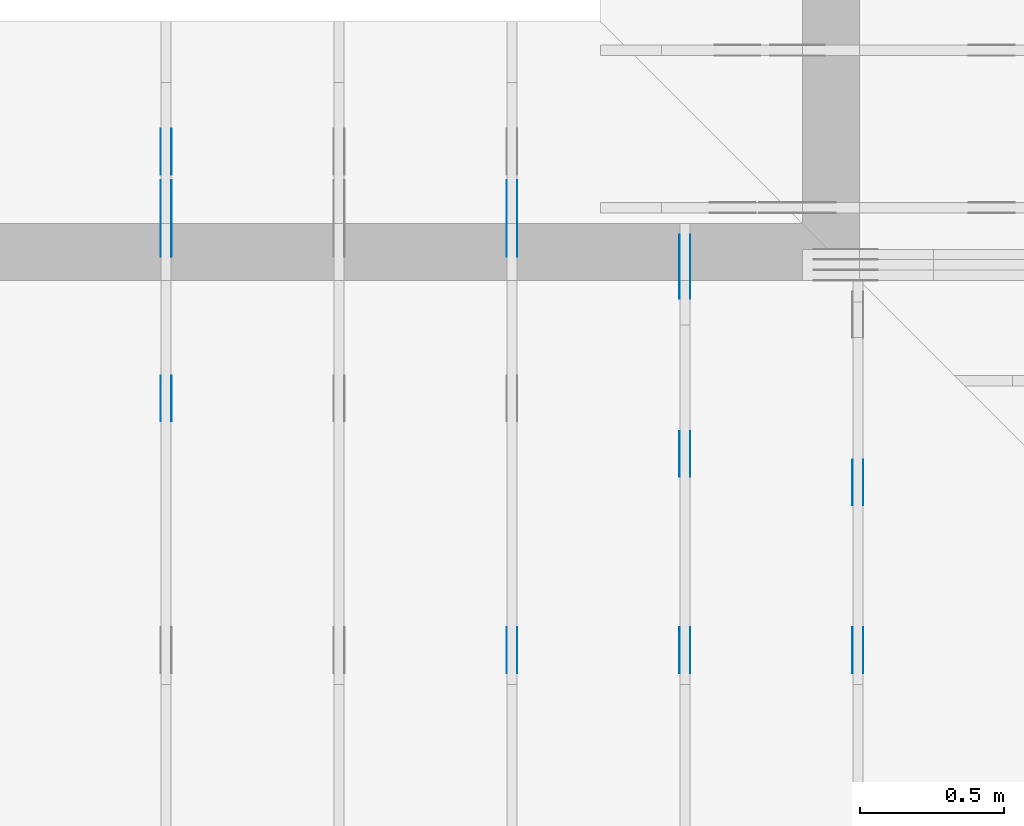
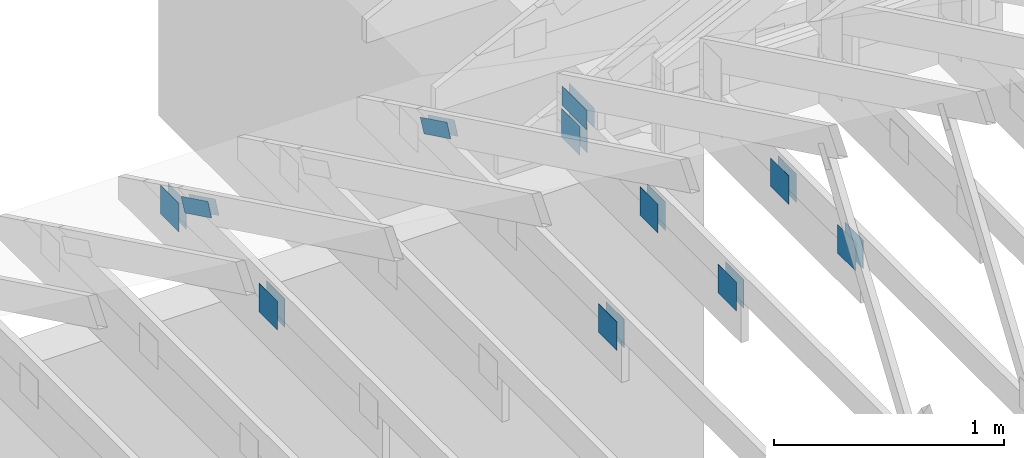
# One storey, part 96 of 159: 22 plates, 4 elements without a shape of their own.
"""IFC2X3 building model written with IfcOpenShell, lengths in millimetres."""

from ifc_helpers import new_model, si_unit, frame, origin, origin_with_axes, origin_2d, place, context, project, spatial, faceted_brep, element, aggregate, save


model = new_model("IFC2X3")

# Units and contexts
model_context = context("Model", 3, precision=1e-05, world=origin())
plan_context = context("Plan", 2, precision=1e-05, world=origin_2d())
ifc_project = project(units=[si_unit("LENGTHUNIT", "METRE", prefix="MILLI"), si_unit("AREAUNIT", "SQUARE_METRE"), si_unit("VOLUMEUNIT", "CUBIC_METRE"), si_unit("SOLIDANGLEUNIT", "STERADIAN"), si_unit("PLANEANGLEUNIT", "RADIAN"), si_unit("MASSUNIT", "GRAM"), si_unit("TIMEUNIT", "SECOND"), si_unit("THERMODYNAMICTEMPERATUREUNIT", "DEGREE_CELSIUS"), si_unit("LUMINOUSINTENSITYUNIT", "LUMEN")], contexts=[model_context, plan_context])

# Site, building, storey
site_placement = place(None, origin_with_axes())
site = spatial("IfcSite", under=ifc_project, at=site_placement, CompositionType="ELEMENT")
building_placement = place(site_placement, origin_with_axes())
building = spatial("IfcBuilding", under=site, at=building_placement, Name="Plan 1", CompositionType="ELEMENT")
storey_placement = place(building_placement, origin_with_axes())
storey = spatial("IfcBuildingStorey", under=building, at=storey_placement, Name="Etasje 1", CompositionType="ELEMENT", Elevation=0.0)

# Assembly, plates
assembly_1_placement = place(storey_placement, frame((10875.02226140475, -699.9989301294845, 1.1021457184401395e-15), z_axis=(-1.0, 1.836909530733566e-16, 6.123031769111886e-17), x_axis=(-1.836909530733566e-16, -1.0, 0.0)))
assembly_1 = element("IfcElementAssembly", 1, at=assembly_1_placement, inside=storey, Name="T4 (96)", AssemblyPlace="FACTORY", PredefinedType="TRUSS")
plate_1_placement = place(assembly_1_placement, frame((-8880.4990234375, 147.0, 0.0), z_axis=(0.0, 0.0, 1.0), x_axis=(1.0, 0.0, 0.0)))
plate_1 = element("IfcPlate", 2, at=plate_1_placement, Name="GNT100S 152x159", context=model_context, shape_type="Brep", body=[
    faceted_brep([(159.0, 152.0, 1.0), (0.0, 152.0, 1.0), (0.0, 0.0, 1.0), (159.0, 0.0, 1.0), (0.0, 152.0, 0.0), (159.0, 152.0, 1.9471241025775798e-14), (159.0, 0.0, 1.9471241025775798e-14), (0.0, 0.0, 0.0), (159.00009331759065, -2.9206878680260863e-14, 1.7883464603583392e-30), (159.00009331759065, -2.9145648362569744e-14, 1.0), (9.331759065389633e-05, 6.121317609395314e-17, 1.0), (9.331759065389633e-05, -1.714159716572357e-20, 1.0495854401904369e-36), (159.00009331759065, 152.0, 0.0), (159.00009331759065, 152.0, 1.0), (159.00009331759065, 0.0, 1.0), (159.00009331759065, 0.0, 0.0), (9.331759065389633e-05, 152.0, 0.0), (9.331759065389633e-05, 152.0, 1.0), (159.00009331759065, 152.0, 1.0), (159.00009331759065, 152.0, 0.0), (9.331759065389633e-05, 0.0, 0.0), (9.331759065395756e-05, -7.498303609110687e-33, 1.0), (9.331759067257158e-05, 152.0, 1.0), (9.331759067251035e-05, 152.0, -1.1397420192804459e-30)], [[[0, 1, 2, 3]], [[4, 5, 6, 7]], [[8, 9, 10, 11]], [[12, 13, 14, 15]], [[16, 17, 18, 19]], [[20, 21, 22, 23]]]),
])
plate_2_placement = place(assembly_1_placement, frame((-8880.4990234375, 147.0, -37.0), z_axis=(0.0, 0.0, 1.0), x_axis=(1.0, 0.0, 0.0)))
plate_2 = element("IfcPlate", 3, at=plate_2_placement, Name="GNT100S 152x159", context=model_context, shape_type="Brep", body=[
    faceted_brep([(159.0, 152.0, 1.0), (0.0, 152.0, 1.0), (0.0, 0.0, 1.0), (159.0, 0.0, 1.0), (0.0, 152.0, 0.0), (159.0, 152.0, 1.9471241025775798e-14), (159.0, 0.0, 1.9471241025775798e-14), (0.0, 0.0, 0.0), (159.00009331759065, -2.9206878680260863e-14, 1.7883464603583392e-30), (159.00009331759065, -2.9145648362569744e-14, 1.0), (9.331759065389633e-05, 6.121317609395314e-17, 1.0), (9.331759065389633e-05, -1.714159716572357e-20, 1.0495854401904369e-36), (159.00009331759065, 152.0, 0.0), (159.00009331759065, 152.0, 1.0), (159.00009331759065, 0.0, 1.0), (159.00009331759065, 0.0, 0.0), (9.331759065389633e-05, 152.0, 0.0), (9.331759065389633e-05, 152.0, 1.0), (159.00009331759065, 152.0, 1.0), (159.00009331759065, 152.0, 0.0), (9.331759065389633e-05, 0.0, 0.0), (9.331759065395756e-05, -7.498303609110687e-33, 1.0), (9.331759067257158e-05, 152.0, 1.0), (9.331759067251035e-05, 152.0, -1.1397420192804459e-30)], [[[0, 1, 2, 3]], [[4, 5, 6, 7]], [[8, 9, 10, 11]], [[12, 13, 14, 15]], [[16, 17, 18, 19]], [[20, 21, 22, 23]]]),
])
plate_3_placement = place(assembly_1_placement, frame((-8139.998930119909, 299.0, 0.0), z_axis=(0.0, 0.0, 1.0), x_axis=(-1.0, 1.2246063538223773e-16, 0.0)))
plate_3 = element("IfcPlate", 4, at=plate_3_placement, Name="GNT100S 152x159", context=model_context, shape_type="Brep", body=[
    faceted_brep([(159.00009331759065, 151.99999999999997, 1.0), (9.331759065389633e-05, 151.99999999999997, 1.0), (9.331759065389633e-05, 0.0, 1.0), (159.00009331759065, 0.0, 1.0), (9.331759065389633e-05, 151.99999999999997, 1.1427731443815714e-20), (159.00009331759065, 151.99999999999997, 1.9471252453507242e-14), (159.00009331759065, 0.0, 1.9471252453507242e-14), (9.331759065389633e-05, 0.0, 1.1427731443815714e-20), (159.0, -2.92068615386637e-14, 1.788345410772899e-30), (159.0, -2.914563122097258e-14, 1.0), (1.1247455413666031e-32, 6.123031769111886e-17, 1.0), (0.0, 0.0, 0.0), (159.0, 152.0, 0.0), (159.0, 152.0, 1.0), (159.0, 0.0, 1.0), (159.0, 0.0, 0.0), (0.0, 151.99999999999997, 0.0), (0.0, 151.99999999999997, 1.0), (159.0, 152.0, 1.0), (159.0, 152.0, 0.0), (0.0, 0.0, 0.0), (6.123031769111886e-17, -7.498303609110687e-33, 1.0), (1.867524689579125e-14, 151.99999999999997, 1.0), (1.861401657810013e-14, 151.99999999999997, -1.1397421485848243e-30)], [[[0, 1, 2, 3]], [[4, 5, 6, 7]], [[8, 9, 10, 11]], [[12, 13, 14, 15]], [[16, 17, 18, 19]], [[20, 21, 22, 23]]]),
])
plate_4_placement = place(assembly_1_placement, frame((-8139.998930119909, 299.0, -37.0), z_axis=(0.0, 0.0, 1.0), x_axis=(-1.0, 1.2246063538223773e-16, 0.0)))
plate_4 = element("IfcPlate", 5, at=plate_4_placement, Name="GNT100S 152x159", context=model_context, shape_type="Brep", body=[
    faceted_brep([(159.00009331759065, 151.99999999999997, 1.0), (9.331759065389633e-05, 151.99999999999997, 1.0), (9.331759065389633e-05, 0.0, 1.0), (159.00009331759065, 0.0, 1.0), (9.331759065389633e-05, 151.99999999999997, 1.1427731443815714e-20), (159.00009331759065, 151.99999999999997, 1.9471252453507242e-14), (159.00009331759065, 0.0, 1.9471252453507242e-14), (9.331759065389633e-05, 0.0, 1.1427731443815714e-20), (159.0, -2.92068615386637e-14, 1.788345410772899e-30), (159.0, -2.914563122097258e-14, 1.0), (1.1247455413666031e-32, 6.123031769111886e-17, 1.0), (0.0, 0.0, 0.0), (159.0, 152.0, 0.0), (159.0, 152.0, 1.0), (159.0, 0.0, 1.0), (159.0, 0.0, 0.0), (0.0, 151.99999999999997, 0.0), (0.0, 151.99999999999997, 1.0), (159.0, 152.0, 1.0), (159.0, 152.0, 0.0), (0.0, 0.0, 0.0), (6.123031769111886e-17, -7.498303609110687e-33, 1.0), (1.867524689579125e-14, 151.99999999999997, 1.0), (1.861401657810013e-14, 151.99999999999997, -1.1397421485848243e-30)], [[[0, 1, 2, 3]], [[4, 5, 6, 7]], [[8, 9, 10, 11]], [[12, 13, 14, 15]], [[16, 17, 18, 19]], [[20, 21, 22, 23]]]),
])
aggregate(assembly_1, [plate_1, plate_2, plate_3, plate_4])

assembly_2_placement = place(storey_placement, frame((10275.02226140475, -699.9989301294845, 1.1021457184401395e-15), z_axis=(-1.0, 1.836909530733566e-16, 6.123031769111886e-17), x_axis=(-1.836909530733566e-16, -1.0, 0.0)))
assembly_2 = element("IfcElementAssembly", 6, at=assembly_2_placement, inside=storey, Name="T3 (95)", AssemblyPlace="FACTORY", PredefinedType="TRUSS")
plate_5_placement = place(assembly_2_placement, frame((-9656.759102067255, 319.5, 0.0), z_axis=(0.0, 0.0, 1.0), x_axis=(1.0, 0.0, 0.0)))
plate_5 = element("IfcPlate", 7, at=plate_5_placement, Name="GNT100S 103x218", context=model_context, shape_type="Brep", body=[
    faceted_brep([(218.0003130047553, 103.0, 1.0), (0.00031300475529860705, 103.0, 1.0), (0.00031300475529860705, 0.0, 1.0), (218.0003130047553, 0.0, 1.0), (0.00031300475529860705, 103.0, 3.833076121152926e-20), (218.0003130047553, 103.0, 2.6696456844089035e-14), (218.0003130047553, 0.0, 2.6696456844089035e-14), (0.00031300475529860705, 0.0, 3.833076121152926e-20), (218.0, -4.0044627769991736e-14, 2.4519452801791947e-30), (218.0, -3.998339745230062e-14, 1.0), (1.1247455413666031e-32, 6.123031769111886e-17, 1.0), (0.0, 0.0, 0.0), (218.0, 103.0, 0.0), (218.0, 103.0, 1.0), (218.0, 0.0, 1.0), (218.0, 0.0, 0.0), (0.0, 103.0, 0.0), (-3.7491518045553436e-33, 103.0, 1.0), (218.0, 102.99999999999999, 1.0), (218.0, 102.99999999999999, -7.888609052210118e-31), (0.0, 0.0, 0.0), (6.123031769111886e-17, -7.498303609110687e-33, 1.0), (1.2674675762061605e-14, 103.0, 1.0), (1.2613445444370486e-14, 103.0, -7.723252717384008e-31)], [[[0, 1, 2, 3]], [[4, 5, 6, 7]], [[8, 9, 10, 11]], [[12, 13, 14, 15]], [[16, 17, 18, 19]], [[20, 21, 22, 23]]]),
])
plate_6_placement = place(assembly_2_placement, frame((-9656.759102067255, 319.5, -37.0), z_axis=(0.0, 0.0, 1.0), x_axis=(1.0, 0.0, 0.0)))
plate_6 = element("IfcPlate", 8, at=plate_6_placement, Name="GNT100S 103x218", context=model_context, shape_type="Brep", body=[
    faceted_brep([(218.0003130047553, 103.0, 1.0), (0.00031300475529860705, 103.0, 1.0), (0.00031300475529860705, 0.0, 1.0), (218.0003130047553, 0.0, 1.0), (0.00031300475529860705, 103.0, 3.833076121152926e-20), (218.0003130047553, 103.0, 2.6696456844089035e-14), (218.0003130047553, 0.0, 2.6696456844089035e-14), (0.00031300475529860705, 0.0, 3.833076121152926e-20), (218.0, -4.0044627769991736e-14, 2.4519452801791947e-30), (218.0, -3.998339745230062e-14, 1.0), (1.1247455413666031e-32, 6.123031769111886e-17, 1.0), (0.0, 0.0, 0.0), (218.0, 103.0, 0.0), (218.0, 103.0, 1.0), (218.0, 0.0, 1.0), (218.0, 0.0, 0.0), (0.0, 103.0, 0.0), (-3.7491518045553436e-33, 103.0, 1.0), (218.0, 102.99999999999999, 1.0), (218.0, 102.99999999999999, -7.888609052210118e-31), (0.0, 0.0, 0.0), (6.123031769111886e-17, -7.498303609110687e-33, 1.0), (1.2674675762061605e-14, 103.0, 1.0), (1.2613445444370486e-14, 103.0, -7.723252717384008e-31)], [[[0, 1, 2, 3]], [[4, 5, 6, 7]], [[8, 9, 10, 11]], [[12, 13, 14, 15]], [[16, 17, 18, 19]], [[20, 21, 22, 23]]]),
])
plate_7_placement = place(assembly_2_placement, frame((-8139.998930129455, 299.0, 0.0), z_axis=(0.0, 0.0, 1.0), x_axis=(-1.0, 1.2246063538223773e-16, 0.0)))
plate_7 = element("IfcPlate", 9, at=plate_7_placement, Name="GNT100S 152x159", context=model_context, shape_type="Brep", body=[
    faceted_brep([(159.0000933080446, 151.99999999999997, 1.0), (9.330804459750652e-05, 151.99999999999997, 1.0), (9.330804459750652e-05, 0.0, 1.0), (159.0000933080446, 0.0, 1.0), (9.330804459750652e-05, 151.99999999999997, 1.1426562427684823e-20), (159.0000933080446, 151.99999999999997, 1.9471252452338226e-14), (159.0000933080446, 0.0, 1.9471252452338226e-14), (9.330804459750652e-05, 0.0, 1.1426562427684823e-20), (159.0, -2.92068615386637e-14, 1.788345410772899e-30), (159.0, -2.914563122097258e-14, 1.0), (1.1247455413666031e-32, 6.123031769111886e-17, 1.0), (0.0, 0.0, 0.0), (159.0, 152.0, 0.0), (159.0, 152.0, 1.0), (159.0, 0.0, 1.0), (159.0, 0.0, 0.0), (0.0, 151.99999999999997, 0.0), (0.0, 151.99999999999997, 1.0), (159.0, 152.0, 1.0), (159.0, 152.0, 0.0), (0.0, 0.0, 0.0), (6.123031769111886e-17, -7.498303609110687e-33, 1.0), (1.867524689579125e-14, 151.99999999999997, 1.0), (1.861401657810013e-14, 151.99999999999997, -1.1397421485848243e-30)], [[[0, 1, 2, 3]], [[4, 5, 6, 7]], [[8, 9, 10, 11]], [[12, 13, 14, 15]], [[16, 17, 18, 19]], [[20, 21, 22, 23]]]),
])
plate_8_placement = place(assembly_2_placement, frame((-8139.998930129455, 299.0, -37.0), z_axis=(0.0, 0.0, 1.0), x_axis=(-1.0, 1.2246063538223773e-16, 0.0)))
plate_8 = element("IfcPlate", 10, at=plate_8_placement, Name="GNT100S 152x159", context=model_context, shape_type="Brep", body=[
    faceted_brep([(159.0000933080446, 151.99999999999997, 1.0), (9.330804459750652e-05, 151.99999999999997, 1.0), (9.330804459750652e-05, 0.0, 1.0), (159.0000933080446, 0.0, 1.0), (9.330804459750652e-05, 151.99999999999997, 1.1426562427684823e-20), (159.0000933080446, 151.99999999999997, 1.9471252452338226e-14), (159.0000933080446, 0.0, 1.9471252452338226e-14), (9.330804459750652e-05, 0.0, 1.1426562427684823e-20), (159.0, -2.92068615386637e-14, 1.788345410772899e-30), (159.0, -2.914563122097258e-14, 1.0), (1.1247455413666031e-32, 6.123031769111886e-17, 1.0), (0.0, 0.0, 0.0), (159.0, 152.0, 0.0), (159.0, 152.0, 1.0), (159.0, 0.0, 1.0), (159.0, 0.0, 0.0), (0.0, 151.99999999999997, 0.0), (0.0, 151.99999999999997, 1.0), (159.0, 152.0, 1.0), (159.0, 152.0, 0.0), (0.0, 0.0, 0.0), (6.123031769111886e-17, -7.498303609110687e-33, 1.0), (1.867524689579125e-14, 151.99999999999997, 1.0), (1.861401657810013e-14, 151.99999999999997, -1.1397421485848243e-30)], [[[0, 1, 2, 3]], [[4, 5, 6, 7]], [[8, 9, 10, 11]], [[12, 13, 14, 15]], [[16, 17, 18, 19]], [[20, 21, 22, 23]]]),
])
plate_9_placement = place(assembly_2_placement, frame((-8979.4990234375, 147.0, 0.0), z_axis=(0.0, 0.0, 1.0), x_axis=(1.0, 0.0, 0.0)))
plate_9 = element("IfcPlate", 11, at=plate_9_placement, Name="GNT100S 152x159", context=model_context, shape_type="Brep", body=[
    faceted_brep([(159.0, 152.0, 1.0), (0.0, 152.0, 1.0), (0.0, 0.0, 1.0), (159.0, 0.0, 1.0), (0.0, 152.0, 0.0), (159.0, 152.0, 1.9471241025775798e-14), (159.0, 0.0, 1.9471241025775798e-14), (0.0, 0.0, 0.0), (159.0000933080446, 5.6058249612704683e-14, 1.7883464602509703e-30), (159.0000933080446, 5.61194799303958e-14, 1.0), (9.330804459750652e-05, 8.532634146905949e-14, 1.0), (9.330804459750652e-05, 8.526511115136837e-14, 1.0494780714342263e-36), (159.0000933080446, 152.0000000000001, 0.0), (159.0000933080446, 152.0000000000001, 1.0), (159.0000933080446, 8.526512829121202e-14, 1.0), (159.0000933080446, 8.526512829121202e-14, 0.0), (9.330804459750652e-05, 152.0000000000001, 0.0), (9.330804459750652e-05, 152.0000000000001, 1.0), (159.0000933080446, 152.0000000000001, 1.0), (159.0000933080446, 152.0000000000001, 0.0), (9.330804459750652e-05, 8.526512829121202e-14, 0.0), (9.330804459756775e-05, 8.526512829121202e-14, 1.0), (9.330804461618177e-05, 152.0000000000001, 1.0), (9.330804461612054e-05, 152.0000000000001, -1.1397420192804459e-30)], [[[0, 1, 2, 3]], [[4, 5, 6, 7]], [[8, 9, 10, 11]], [[12, 13, 14, 15]], [[16, 17, 18, 19]], [[20, 21, 22, 23]]]),
])
plate_10_placement = place(assembly_2_placement, frame((-8979.4990234375, 147.0, -37.0), z_axis=(0.0, 0.0, 1.0), x_axis=(1.0, 0.0, 0.0)))
plate_10 = element("IfcPlate", 12, at=plate_10_placement, Name="GNT100S 152x159", context=model_context, shape_type="Brep", body=[
    faceted_brep([(159.0, 152.0, 1.0), (0.0, 152.0, 1.0), (0.0, 0.0, 1.0), (159.0, 0.0, 1.0), (0.0, 152.0, 0.0), (159.0, 152.0, 1.9471241025775798e-14), (159.0, 0.0, 1.9471241025775798e-14), (0.0, 0.0, 0.0), (159.0000933080446, 5.6058249612704683e-14, 1.7883464602509703e-30), (159.0000933080446, 5.61194799303958e-14, 1.0), (9.330804459750652e-05, 8.532634146905949e-14, 1.0), (9.330804459750652e-05, 8.526511115136837e-14, 1.0494780714342263e-36), (159.0000933080446, 152.0000000000001, 0.0), (159.0000933080446, 152.0000000000001, 1.0), (159.0000933080446, 8.526512829121202e-14, 1.0), (159.0000933080446, 8.526512829121202e-14, 0.0), (9.330804459750652e-05, 152.0000000000001, 0.0), (9.330804459750652e-05, 152.0000000000001, 1.0), (159.0000933080446, 152.0000000000001, 1.0), (159.0000933080446, 152.0000000000001, 0.0), (9.330804459750652e-05, 8.526512829121202e-14, 0.0), (9.330804459756775e-05, 8.526512829121202e-14, 1.0), (9.330804461618177e-05, 152.0000000000001, 1.0), (9.330804461612054e-05, 152.0000000000001, -1.1397420192804459e-30)], [[[0, 1, 2, 3]], [[4, 5, 6, 7]], [[8, 9, 10, 11]], [[12, 13, 14, 15]], [[16, 17, 18, 19]], [[20, 21, 22, 23]]]),
])
plate_11_placement = place(assembly_2_placement, frame((-9659.9990234375, 147.0, 0.0), z_axis=(0.0, 0.0, 1.0), x_axis=(1.0, 0.0, 0.0)))
plate_11 = element("IfcPlate", 13, at=plate_11_placement, Name="GNT100S 152x159", context=model_context, shape_type="Brep", body=[
    faceted_brep([(159.0, 152.0, 1.0), (0.0, 152.0, 1.0), (0.0, 0.0, 1.0), (159.0, 0.0, 1.0), (0.0, 152.0, 0.0), (159.0, 152.0, 1.9471241025775798e-14), (159.0, 0.0, 1.9471241025775798e-14), (0.0, 0.0, 0.0), (159.0000933080446, 1.697450873343207e-13, 1.7883464602509703e-30), (159.0000933080446, 1.6980631765201183e-13, 1.0), (9.330804459750652e-05, 1.9901317919067552e-13, 1.0), (9.330804459750652e-05, 1.989519488729844e-13, 1.0494780714342263e-36), (159.0000933080446, 152.00000000000023, 0.0), (159.0000933080446, 152.00000000000023, 1.0), (159.0000933080446, 1.9895196601282805e-13, 1.0), (159.0000933080446, 1.9895196601282805e-13, 0.0), (9.330804459750652e-05, 152.00000000000023, 0.0), (9.330804459750652e-05, 152.00000000000023, 1.0), (159.0000933080446, 152.00000000000023, 1.0), (159.0000933080446, 152.00000000000023, 0.0), (9.330804459750652e-05, 1.9895196601282805e-13, 0.0), (9.330804459756775e-05, 1.9895196601282805e-13, 1.0), (9.330804461618177e-05, 152.00000000000023, 1.0), (9.330804461612054e-05, 152.00000000000023, -1.1397420192804459e-30)], [[[0, 1, 2, 3]], [[4, 5, 6, 7]], [[8, 9, 10, 11]], [[12, 13, 14, 15]], [[16, 17, 18, 19]], [[20, 21, 22, 23]]]),
])
plate_12_placement = place(assembly_2_placement, frame((-9659.9990234375, 147.0, -37.0), z_axis=(0.0, 0.0, 1.0), x_axis=(1.0, 0.0, 0.0)))
plate_12 = element("IfcPlate", 14, at=plate_12_placement, Name="GNT100S 152x159", context=model_context, shape_type="Brep", body=[
    faceted_brep([(159.0, 152.0, 1.0), (0.0, 152.0, 1.0), (0.0, 0.0, 1.0), (159.0, 0.0, 1.0), (0.0, 152.0, 0.0), (159.0, 152.0, 1.9471241025775798e-14), (159.0, 0.0, 1.9471241025775798e-14), (0.0, 0.0, 0.0), (159.0000933080446, 1.697450873343207e-13, 1.7883464602509703e-30), (159.0000933080446, 1.6980631765201183e-13, 1.0), (9.330804459750652e-05, 1.9901317919067552e-13, 1.0), (9.330804459750652e-05, 1.989519488729844e-13, 1.0494780714342263e-36), (159.0000933080446, 152.00000000000023, 0.0), (159.0000933080446, 152.00000000000023, 1.0), (159.0000933080446, 1.9895196601282805e-13, 1.0), (159.0000933080446, 1.9895196601282805e-13, 0.0), (9.330804459750652e-05, 152.00000000000023, 0.0), (9.330804459750652e-05, 152.00000000000023, 1.0), (159.0000933080446, 152.00000000000023, 1.0), (159.0000933080446, 152.00000000000023, 0.0), (9.330804459750652e-05, 1.9895196601282805e-13, 0.0), (9.330804459756775e-05, 1.9895196601282805e-13, 1.0), (9.330804461618177e-05, 152.00000000000023, 1.0), (9.330804461612054e-05, 152.00000000000023, -1.1397420192804459e-30)], [[[0, 1, 2, 3]], [[4, 5, 6, 7]], [[8, 9, 10, 11]], [[12, 13, 14, 15]], [[16, 17, 18, 19]], [[20, 21, 22, 23]]]),
])
aggregate(assembly_2, [plate_5, plate_6, plate_7, plate_8, plate_9, plate_10, plate_11, plate_12])

assembly_3_placement = place(storey_placement, frame((9675.022261404752, 9699.99999999999, 1.1021457184401395e-15), z_axis=(-1.0, 1.836909530733566e-16, 6.123031769111886e-17), x_axis=(-1.836909530733566e-16, -1.0, 0.0)))
assembly_3 = element("IfcElementAssembly", 15, at=assembly_3_placement, inside=storey, Name="T2 (94)", AssemblyPlace="FACTORY", PredefinedType="TRUSS")
plate_13_placement = place(assembly_3_placement, frame((584.1466632894789, 280.2959373746887, 0.0), z_axis=(0.0, 0.0, 1.0), x_axis=(0.8987940462991671, 0.43837114678907757, 0.0)))
plate_13 = element("IfcPlate", 16, at=plate_13_placement, Name="GNT100S 76x258", context=model_context, shape_type="Brep", body=[
    faceted_brep([(257.99998123479463, 76.00002691228985, 1.0), (0.0, 76.00002691228985, 1.0), (1.3453948213282274e-05, 1.802431262376558e-05, 1.0), (257.99999468874273, 1.802431262376558e-05, 1.0), (0.0, 76.00002691228985, 0.0), (257.99998123479463, 76.00002691228985, 3.159484163061836e-14), (257.99999468874273, 0.0, 3.1594843278197396e-14), (1.3453948213282274e-05, 0.0, 1.6475790465982693e-21), (258.00000746284013, 8.521039129974861e-06, 1.1615733003639174e-30), (258.00000746284013, 8.521039130036092e-06, 1.0), (7.462840130756376e-06, 8.521039177428358e-06, 1.0), (7.462840130756376e-06, 8.521039177367127e-06, 9.4039548065783e-38), (258.00000746284013, 76.00000852103915, 0.0), (258.00000746284013, 76.00000852103915, 1.0), (258.00000746284013, 8.52103914894542e-06, 1.0), (258.00000746284013, 8.52103914894542e-06, 0.0), (7.462840130756376e-06, 76.0000085210392, 0.0), (7.462840130756376e-06, 76.0000085210392, 1.0), (258.00000746284013, 76.00000852103913, 1.0), (258.00000746284013, 76.00000852103913, -1.5777218104420236e-30), (7.462840130756377e-06, 8.521039177367129e-06, -9.4039548065783e-38), (7.4628401308176075e-06, 8.521039177367129e-06, 1.0), (7.462840140124616e-06, 76.0000085210392, 1.0), (7.4628401400633854e-06, 76.0000085210392, -5.69871103679771e-31)], [[[0, 1, 2, 3]], [[4, 5, 6, 7]], [[8, 9, 10, 11]], [[12, 13, 14, 15]], [[16, 17, 18, 19]], [[20, 21, 22, 23]]]),
])
plate_14_placement = place(assembly_3_placement, frame((584.1466632894789, 280.2959373746887, -37.0), z_axis=(0.0, 0.0, 1.0), x_axis=(0.8987940462991671, 0.43837114678907757, 0.0)))
plate_14 = element("IfcPlate", 17, at=plate_14_placement, Name="GNT100S 76x258", context=model_context, shape_type="Brep", body=[
    faceted_brep([(257.99998123479463, 76.00002691228985, 1.0), (0.0, 76.00002691228985, 1.0), (1.3453948213282274e-05, 1.802431262376558e-05, 1.0), (257.99999468874273, 1.802431262376558e-05, 1.0), (0.0, 76.00002691228985, 0.0), (257.99998123479463, 76.00002691228985, 3.159484163061836e-14), (257.99999468874273, 0.0, 3.1594843278197396e-14), (1.3453948213282274e-05, 0.0, 1.6475790465982693e-21), (258.00000746284013, 8.521039129974861e-06, 1.1615733003639174e-30), (258.00000746284013, 8.521039130036092e-06, 1.0), (7.462840130756376e-06, 8.521039177428358e-06, 1.0), (7.462840130756376e-06, 8.521039177367127e-06, 9.4039548065783e-38), (258.00000746284013, 76.00000852103915, 0.0), (258.00000746284013, 76.00000852103915, 1.0), (258.00000746284013, 8.52103914894542e-06, 1.0), (258.00000746284013, 8.52103914894542e-06, 0.0), (7.462840130756376e-06, 76.0000085210392, 0.0), (7.462840130756376e-06, 76.0000085210392, 1.0), (258.00000746284013, 76.00000852103913, 1.0), (258.00000746284013, 76.00000852103913, -1.5777218104420236e-30), (7.462840130756377e-06, 8.521039177367129e-06, -9.4039548065783e-38), (7.4628401308176075e-06, 8.521039177367129e-06, 1.0), (7.462840140124616e-06, 76.0000085210392, 1.0), (7.4628401400633854e-06, 76.0000085210392, -5.69871103679771e-31)], [[[0, 1, 2, 3]], [[4, 5, 6, 7]], [[8, 9, 10, 11]], [[12, 13, 14, 15]], [[16, 17, 18, 19]], [[20, 21, 22, 23]]]),
])
plate_15_placement = place(assembly_3_placement, frame((2260.0, 299.0, 0.0), z_axis=(0.0, 0.0, 1.0), x_axis=(-1.0, 1.2246063538223773e-16, 0.0)))
plate_15 = element("IfcPlate", 18, at=plate_15_placement, Name="GNT100S 152x159", context=model_context, shape_type="Brep", body=[
    faceted_brep([(159.0, 152.0, 1.0), (0.0, 152.0, 1.0), (0.0, 0.0, 1.0), (159.0, 0.0, 1.0), (0.0, 152.0, 0.0), (159.0, 152.0, 1.9471241025775798e-14), (159.0, 0.0, 1.9471241025775798e-14), (0.0, 0.0, 0.0), (159.0, -2.92068615386637e-14, 1.788345410772899e-30), (159.0, -2.914563122097258e-14, 1.0), (1.1247455413666031e-32, 6.123031769111886e-17, 1.0), (0.0, 0.0, 0.0), (159.0, 152.00000000000003, 0.0), (159.0, 152.00000000000003, 1.0), (159.0, 0.0, 1.0), (159.0, 0.0, 0.0), (0.0, 152.0, 0.0), (0.0, 152.0, 1.0), (159.0, 152.00000000000003, 1.0), (159.0, 152.00000000000003, 0.0), (0.0, 0.0, 0.0), (6.123031769111886e-17, -7.498303609110687e-33, 1.0), (1.8675246895791253e-14, 152.0, 1.0), (1.8614016578100134e-14, 152.0, -1.1397421485848245e-30)], [[[0, 1, 2, 3]], [[4, 5, 6, 7]], [[8, 9, 10, 11]], [[12, 13, 14, 15]], [[16, 17, 18, 19]], [[20, 21, 22, 23]]]),
])
plate_16_placement = place(assembly_3_placement, frame((2260.0, 299.0, -37.0), z_axis=(0.0, 0.0, 1.0), x_axis=(-1.0, 1.2246063538223773e-16, 0.0)))
plate_16 = element("IfcPlate", 19, at=plate_16_placement, Name="GNT100S 152x159", context=model_context, shape_type="Brep", body=[
    faceted_brep([(159.0, 152.0, 1.0), (0.0, 152.0, 1.0), (0.0, 0.0, 1.0), (159.0, 0.0, 1.0), (0.0, 152.0, 0.0), (159.0, 152.0, 1.9471241025775798e-14), (159.0, 0.0, 1.9471241025775798e-14), (0.0, 0.0, 0.0), (159.0, -2.92068615386637e-14, 1.788345410772899e-30), (159.0, -2.914563122097258e-14, 1.0), (1.1247455413666031e-32, 6.123031769111886e-17, 1.0), (0.0, 0.0, 0.0), (159.0, 152.00000000000003, 0.0), (159.0, 152.00000000000003, 1.0), (159.0, 0.0, 1.0), (159.0, 0.0, 0.0), (0.0, 152.0, 0.0), (0.0, 152.0, 1.0), (159.0, 152.00000000000003, 1.0), (159.0, 152.00000000000003, 0.0), (0.0, 0.0, 0.0), (6.123031769111886e-17, -7.498303609110687e-33, 1.0), (1.8675246895791253e-14, 152.0, 1.0), (1.8614016578100134e-14, 152.0, -1.1397421485848245e-30)], [[[0, 1, 2, 3]], [[4, 5, 6, 7]], [[8, 9, 10, 11]], [[12, 13, 14, 15]], [[16, 17, 18, 19]], [[20, 21, 22, 23]]]),
])
aggregate(assembly_3, [plate_13, plate_14, plate_15, plate_16])

assembly_4_placement = place(storey_placement, frame((8475.022261404752, 9699.99999999999, 1.1021457184401395e-15), z_axis=(-1.0, 1.836909530733566e-16, 6.123031769111886e-17), x_axis=(-1.836909530733566e-16, -1.0, 0.0)))
assembly_4 = element("IfcElementAssembly", 20, at=assembly_4_placement, inside=storey, Name="T2 (92)", AssemblyPlace="FACTORY", PredefinedType="TRUSS")
plate_17_placement = place(assembly_4_placement, frame((584.1466632894789, 280.2959373746887, 0.0), z_axis=(0.0, 0.0, 1.0), x_axis=(0.8987940462991671, 0.43837114678907757, 0.0)))
plate_17 = element("IfcPlate", 21, at=plate_17_placement, Name="GNT100S 76x258", context=model_context, shape_type="Brep", body=[
    faceted_brep([(257.99998123479463, 76.00002691228985, 1.0), (0.0, 76.00002691228985, 1.0), (1.3453948213282274e-05, 1.802431262376558e-05, 1.0), (257.99999468874273, 1.802431262376558e-05, 1.0), (0.0, 76.00002691228985, 0.0), (257.99998123479463, 76.00002691228985, 3.159484163061836e-14), (257.99999468874273, 0.0, 3.1594843278197396e-14), (1.3453948213282274e-05, 0.0, 1.6475790465982693e-21), (258.00000746284013, 8.521039129974861e-06, 1.1615733003639174e-30), (258.00000746284013, 8.521039130036092e-06, 1.0), (7.462840130756376e-06, 8.521039177428358e-06, 1.0), (7.462840130756376e-06, 8.521039177367127e-06, 9.4039548065783e-38), (258.00000746284013, 76.00000852103915, 0.0), (258.00000746284013, 76.00000852103915, 1.0), (258.00000746284013, 8.52103914894542e-06, 1.0), (258.00000746284013, 8.52103914894542e-06, 0.0), (7.462840130756376e-06, 76.0000085210392, 0.0), (7.462840130756376e-06, 76.0000085210392, 1.0), (258.00000746284013, 76.00000852103913, 1.0), (258.00000746284013, 76.00000852103913, -1.5777218104420236e-30), (7.462840130756377e-06, 8.521039177367129e-06, -9.4039548065783e-38), (7.4628401308176075e-06, 8.521039177367129e-06, 1.0), (7.462840140124616e-06, 76.0000085210392, 1.0), (7.4628401400633854e-06, 76.0000085210392, -5.69871103679771e-31)], [[[0, 1, 2, 3]], [[4, 5, 6, 7]], [[8, 9, 10, 11]], [[12, 13, 14, 15]], [[16, 17, 18, 19]], [[20, 21, 22, 23]]]),
])
plate_18_placement = place(assembly_4_placement, frame((584.1466632894789, 280.2959373746887, -37.0), z_axis=(0.0, 0.0, 1.0), x_axis=(0.8987940462991671, 0.43837114678907757, 0.0)))
plate_18 = element("IfcPlate", 22, at=plate_18_placement, Name="GNT100S 76x258", context=model_context, shape_type="Brep", body=[
    faceted_brep([(257.99998123479463, 76.00002691228985, 1.0), (0.0, 76.00002691228985, 1.0), (1.3453948213282274e-05, 1.802431262376558e-05, 1.0), (257.99999468874273, 1.802431262376558e-05, 1.0), (0.0, 76.00002691228985, 0.0), (257.99998123479463, 76.00002691228985, 3.159484163061836e-14), (257.99999468874273, 0.0, 3.1594843278197396e-14), (1.3453948213282274e-05, 0.0, 1.6475790465982693e-21), (258.00000746284013, 8.521039129974861e-06, 1.1615733003639174e-30), (258.00000746284013, 8.521039130036092e-06, 1.0), (7.462840130756376e-06, 8.521039177428358e-06, 1.0), (7.462840130756376e-06, 8.521039177367127e-06, 9.4039548065783e-38), (258.00000746284013, 76.00000852103915, 0.0), (258.00000746284013, 76.00000852103915, 1.0), (258.00000746284013, 8.52103914894542e-06, 1.0), (258.00000746284013, 8.52103914894542e-06, 0.0), (7.462840130756376e-06, 76.0000085210392, 0.0), (7.462840130756376e-06, 76.0000085210392, 1.0), (258.00000746284013, 76.00000852103913, 1.0), (258.00000746284013, 76.00000852103913, -1.5777218104420236e-30), (7.462840130756377e-06, 8.521039177367129e-06, -9.4039548065783e-38), (7.4628401308176075e-06, 8.521039177367129e-06, 1.0), (7.462840140124616e-06, 76.0000085210392, 1.0), (7.4628401400633854e-06, 76.0000085210392, -5.69871103679771e-31)], [[[0, 1, 2, 3]], [[4, 5, 6, 7]], [[8, 9, 10, 11]], [[12, 13, 14, 15]], [[16, 17, 18, 19]], [[20, 21, 22, 23]]]),
])
plate_19_placement = place(assembly_4_placement, frame((1227.851282296476, 147.0, 0.0), z_axis=(0.0, 0.0, 1.0), x_axis=(1.0, 0.0, 0.0)))
plate_19 = element("IfcPlate", 23, at=plate_19_placement, Name="GNT100S 152x159", context=model_context, shape_type="Brep", body=[
    faceted_brep([(159.00003606289897, 152.0, 1.0), (3.6062898971067625e-05, 152.0, 1.0), (3.6062898971067625e-05, 0.0, 1.0), (159.00003606289897, 0.0, 1.0), (3.6062898971067625e-05, 152.0, 4.4162855217223885e-21), (159.00003606289897, 152.0, 1.947124544206132e-14), (159.00003606289897, 0.0, 1.947124544206132e-14), (3.6062898971067625e-05, 0.0, 4.4162855217223885e-21), (159.0, 8.447997618295233e-14, 1.788345410772899e-30), (159.0, 8.454120650064345e-14, 1.0), (1.1247455413666031e-32, 1.1374806803930715e-13, 1.0), (0.0, 1.1368683772161603e-13, 0.0), (159.0, 152.0000000000001, 0.0), (159.0, 152.0000000000001, 1.0), (159.0, 1.1368683772161603e-13, 1.0), (159.0, 1.1368683772161603e-13, 0.0), (4.861730685829017e-63, 152.0000000000001, 0.0), (-3.7491518045553436e-33, 152.0000000000001, 1.0), (159.0, 152.0000000000001, 1.0), (159.0, 152.0000000000001, 0.0), (1.392216238198645e-29, 1.1368683772161603e-13, -8.524584255963745e-46), (6.123031769113279e-17, 1.1368683772161603e-13, 1.0), (1.8675246895791266e-14, 152.0000000000001, 1.0), (1.8614016578100147e-14, 152.0000000000001, -1.1397421485848253e-30)], [[[0, 1, 2, 3]], [[4, 5, 6, 7]], [[8, 9, 10, 11]], [[12, 13, 14, 15]], [[16, 17, 18, 19]], [[20, 21, 22, 23]]]),
])
plate_20_placement = place(assembly_4_placement, frame((1227.851282296476, 147.0, -37.0), z_axis=(0.0, 0.0, 1.0), x_axis=(1.0, 0.0, 0.0)))
plate_20 = element("IfcPlate", 24, at=plate_20_placement, Name="GNT100S 152x159", context=model_context, shape_type="Brep", body=[
    faceted_brep([(159.00003606289897, 152.0, 1.0), (3.6062898971067625e-05, 152.0, 1.0), (3.6062898971067625e-05, 0.0, 1.0), (159.00003606289897, 0.0, 1.0), (3.6062898971067625e-05, 152.0, 4.4162855217223885e-21), (159.00003606289897, 152.0, 1.947124544206132e-14), (159.00003606289897, 0.0, 1.947124544206132e-14), (3.6062898971067625e-05, 0.0, 4.4162855217223885e-21), (159.0, 8.447997618295233e-14, 1.788345410772899e-30), (159.0, 8.454120650064345e-14, 1.0), (1.1247455413666031e-32, 1.1374806803930715e-13, 1.0), (0.0, 1.1368683772161603e-13, 0.0), (159.0, 152.0000000000001, 0.0), (159.0, 152.0000000000001, 1.0), (159.0, 1.1368683772161603e-13, 1.0), (159.0, 1.1368683772161603e-13, 0.0), (4.861730685829017e-63, 152.0000000000001, 0.0), (-3.7491518045553436e-33, 152.0000000000001, 1.0), (159.0, 152.0000000000001, 1.0), (159.0, 152.0000000000001, 0.0), (1.392216238198645e-29, 1.1368683772161603e-13, -8.524584255963745e-46), (6.123031769113279e-17, 1.1368683772161603e-13, 1.0), (1.8675246895791266e-14, 152.0000000000001, 1.0), (1.8614016578100147e-14, 152.0000000000001, -1.1397421485848253e-30)], [[[0, 1, 2, 3]], [[4, 5, 6, 7]], [[8, 9, 10, 11]], [[12, 13, 14, 15]], [[16, 17, 18, 19]], [[20, 21, 22, 23]]]),
])
plate_21_placement = place(assembly_4_placement, frame((372.12651478826456, 147.0, 0.0), z_axis=(0.0, 0.0, 1.0), x_axis=(1.0, 0.0, 0.0)))
plate_21 = element("IfcPlate", 25, at=plate_21_placement, Name="GNT100S 152x159", context=model_context, shape_type="Brep", body=[
    faceted_brep([(159.0000110906417, 152.0, 1.0), (1.109064169213525e-05, 152.0, 1.0), (1.109064169213525e-05, 0.0, 1.0), (159.0000110906417, 0.0, 1.0), (1.109064169213525e-05, 152.0, 1.3581670284156189e-21), (159.0000110906417, 152.0, 1.9471242383942826e-14), (159.0000110906417, 0.0, 1.9471242383942826e-14), (1.109064169213525e-05, 0.0, 1.3581670284156189e-21), (159.0, 1.9816681390456836e-13, 1.788345410772899e-30), (159.0, 1.9822804422225948e-13, 1.0), (1.1247455413666031e-32, 2.274349057609232e-13, 1.0), (0.0, 2.2737367544323206e-13, 0.0), (159.0, 152.00000000000023, 0.0), (159.0, 152.00000000000023, 1.0), (159.0, 2.2737367544323206e-13, 1.0), (159.0, 2.2737367544323206e-13, 0.0), (0.0, 152.00000000000023, 0.0), (-3.7491518045553436e-33, 152.00000000000023, 1.0), (159.0, 152.00000000000023, 1.0), (159.0, 152.00000000000023, 0.0), (2.78443247639729e-29, 2.2737367544323206e-13, -1.704916851192749e-45), (6.123031769114671e-17, 2.2737367544323206e-13, 1.0), (1.8675246895791282e-14, 152.00000000000023, 1.0), (1.8614016578100163e-14, 152.00000000000023, -1.1397421485848262e-30)], [[[0, 1, 2, 3]], [[4, 5, 6, 7]], [[8, 9, 10, 11]], [[12, 13, 14, 15]], [[16, 17, 18, 19]], [[20, 21, 22, 23]]]),
])
plate_22_placement = place(assembly_4_placement, frame((372.12651478826456, 147.0, -37.0), z_axis=(0.0, 0.0, 1.0), x_axis=(1.0, 0.0, 0.0)))
plate_22 = element("IfcPlate", 26, at=plate_22_placement, Name="GNT100S 152x159", context=model_context, shape_type="Brep", body=[
    faceted_brep([(159.0000110906417, 152.0, 1.0), (1.109064169213525e-05, 152.0, 1.0), (1.109064169213525e-05, 0.0, 1.0), (159.0000110906417, 0.0, 1.0), (1.109064169213525e-05, 152.0, 1.3581670284156189e-21), (159.0000110906417, 152.0, 1.9471242383942826e-14), (159.0000110906417, 0.0, 1.9471242383942826e-14), (1.109064169213525e-05, 0.0, 1.3581670284156189e-21), (159.0, 1.9816681390456836e-13, 1.788345410772899e-30), (159.0, 1.9822804422225948e-13, 1.0), (1.1247455413666031e-32, 2.274349057609232e-13, 1.0), (0.0, 2.2737367544323206e-13, 0.0), (159.0, 152.00000000000023, 0.0), (159.0, 152.00000000000023, 1.0), (159.0, 2.2737367544323206e-13, 1.0), (159.0, 2.2737367544323206e-13, 0.0), (0.0, 152.00000000000023, 0.0), (-3.7491518045553436e-33, 152.00000000000023, 1.0), (159.0, 152.00000000000023, 1.0), (159.0, 152.00000000000023, 0.0), (2.78443247639729e-29, 2.2737367544323206e-13, -1.704916851192749e-45), (6.123031769114671e-17, 2.2737367544323206e-13, 1.0), (1.8675246895791282e-14, 152.00000000000023, 1.0), (1.8614016578100163e-14, 152.00000000000023, -1.1397421485848262e-30)], [[[0, 1, 2, 3]], [[4, 5, 6, 7]], [[8, 9, 10, 11]], [[12, 13, 14, 15]], [[16, 17, 18, 19]], [[20, 21, 22, 23]]]),
])
aggregate(assembly_4, [plate_17, plate_18, plate_19, plate_20, plate_21, plate_22])

save(model, "model.ifc")
